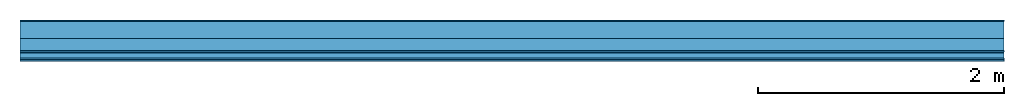
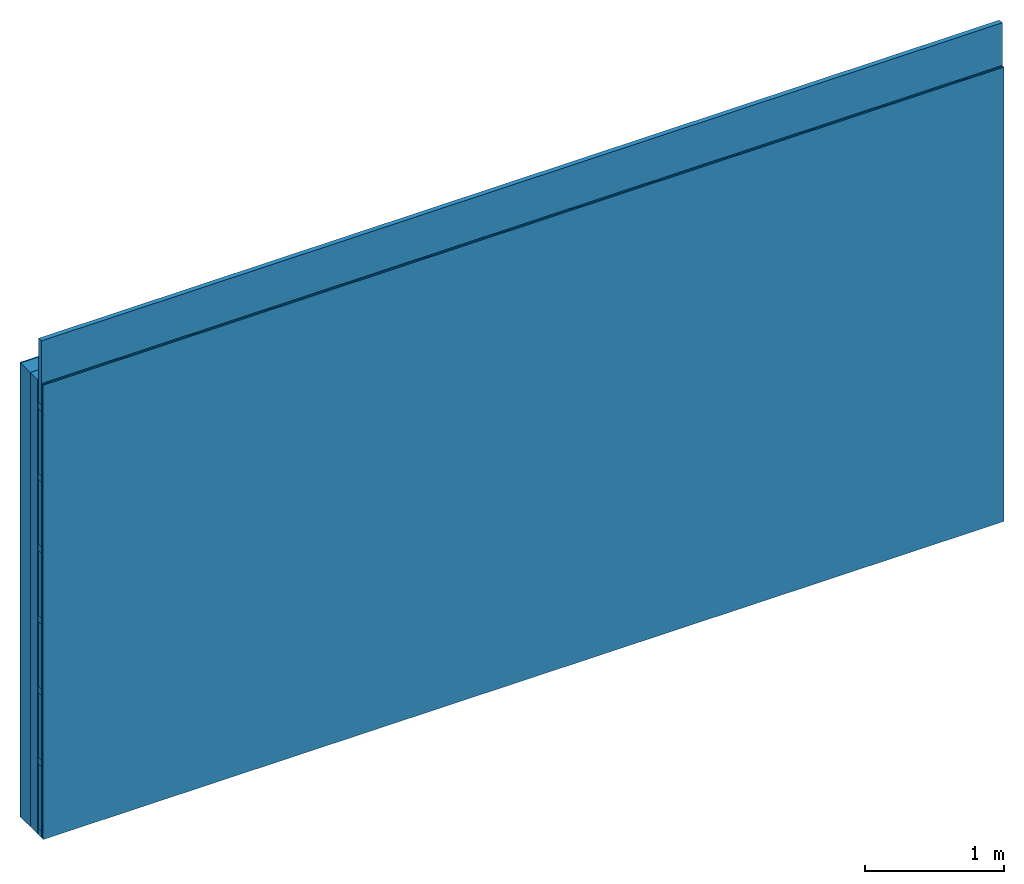
# One storey: 5 plates, 3 members, 1 element without a shape of its own.
"""IFC4 building model written with IfcOpenShell, lengths in metres."""

from ifc_helpers import new_model, si_unit, derived_unit, direction, frame, frame_2d, origin, origin_with_axes, place, context, project, spatial, rectangle, extrude, material, layer, layer_set, type_object, element, aggregate, save


model = new_model("IFC4")

# Units and contexts
plan_context = context("Plan", 3, precision=1e-05, world=origin(), true_north=direction((0.0, 1.0)))
model_context = context("Model", 3, precision=1e-05, world=origin(), true_north=direction((0.0, 1.0)))
ifc_project = project(units=[si_unit("LENGTHUNIT", "METRE"), derived_unit("SOUNDPRESSUREUNIT", [(si_unit("PRESSUREUNIT", "PASCAL", prefix="MICRO"), 0)]), si_unit("ENERGYUNIT", "JOULE", prefix="MEGA"), si_unit("MASSUNIT", "GRAM", prefix="KILO"), derived_unit("THERMALTRANSMITTANCEUNIT", [(si_unit("POWERUNIT", "WATT"), 1), (si_unit("AREAUNIT", "SQUARE_METRE"), -1), (si_unit("THERMODYNAMICTEMPERATUREUNIT", "KELVIN"), -1)]), derived_unit("AREADENSITYUNIT", [(si_unit("MASSUNIT", "GRAM", prefix="KILO"), 1), (si_unit("AREAUNIT", "SQUARE_METRE"), -1)]), derived_unit("USERDEFINED", [(si_unit("ENERGYUNIT", "JOULE", prefix="MEGA"), 1), (si_unit("AREAUNIT", "SQUARE_METRE"), -1)])], contexts=[plan_context, model_context])

# Site, building, storey
site = spatial("IfcSite", under=ifc_project)
building_placement = place(None, origin())
building = spatial("IfcBuilding", under=site, at=building_placement)
storey_placement = place(building_placement, origin())
storey = spatial("IfcBuildingStorey", under=building, at=storey_placement)

# Wall, members, plates
ifc_material_1 = material(Name="Mineral Knauf SM 700")
ifc_layer_1 = layer(ifc_material_1, 0.01, Name="Surface 1")
ifc_material_2 = material(Category="10.008")
ifc_layer_2 = layer(ifc_material_2, 0.14, Name="outside 1st layer")
ifc_material_3 = material(Name="of the art")
ifc_layer_3 = layer(ifc_material_3, 0.0, Name="Bond")
ifc_layer_4 = layer(None, 0.1, Name="Support")
ifc_material_4 = material(Name="Air")
ifc_layer_5 = layer(ifc_material_4, 0.01, Name="Coupling")
ifc_layer_6 = layer(None, 0.05, Name="Battens / profiles")
ifc_material_5 = material(Category="03.008")
ifc_layer_7 = layer(ifc_material_5, 0.0125, Name="Covering 1st layer")
ifc_layer_8 = layer(ifc_material_5, 0.0125, Name="Covering 2nd layer")
ifc_layer_set = layer_set([ifc_layer_1, ifc_layer_2, ifc_layer_3, ifc_layer_4, ifc_layer_5, ifc_layer_6, ifc_layer_7, ifc_layer_8])
wall_type = type_object("IfcWallType", Name="D1198", PredefinedType="NOTDEFINED", material=ifc_layer_set)
wall_placement = place(None, frame((0.0, 0.0, 0.0), z_axis=(0.0, -1.0, 0.0), x_axis=(1.0, 0.0, 0.0)))
wall = element("IfcWall", 1, at=wall_placement, inside=storey, type_object=wall_type, material=ifc_layer_set, Name="Wall #1")
ifc_material_6 = material(Name="OSB")
member_1_placement = place(wall_placement, origin())
member_1 = element("IfcMember", 2, at=member_1_placement, material=ifc_material_6, Name="Support", context=plan_context, shape_type="SweptSolid", body=[
    extrude(rectangle(XDim=1.0, YDim=0.1, at=frame_2d((0.5, 0.05), x_axis=(1.0, 0.0))), frame((0.0, 4.0, 0.15), z_axis=(0.0, -1.0, 0.0), x_axis=(1.0, 0.0, 0.0)), (0.0, 0.0, 1.0), 4.0),
    extrude(rectangle(XDim=1.0, YDim=0.1, at=frame_2d((0.5, 0.05), x_axis=(1.0, 0.0))), frame((1.0, 4.0, 0.15), z_axis=(0.0, -1.0, 0.0), x_axis=(1.0, 0.0, 0.0)), (0.0, 0.0, 1.0), 4.0),
    extrude(rectangle(XDim=1.0, YDim=0.1, at=frame_2d((0.5, 0.05), x_axis=(1.0, 0.0))), frame((2.0, 4.0, 0.15), z_axis=(0.0, -1.0, 0.0), x_axis=(1.0, 0.0, 0.0)), (0.0, 0.0, 1.0), 4.0),
    extrude(rectangle(XDim=1.0, YDim=0.1, at=frame_2d((0.5, 0.05), x_axis=(1.0, 0.0))), frame((3.0, 4.0, 0.15), z_axis=(0.0, -1.0, 0.0), x_axis=(1.0, 0.0, 0.0)), (0.0, 0.0, 1.0), 4.0),
    extrude(rectangle(XDim=1.0, YDim=0.1, at=frame_2d((0.5, 0.05), x_axis=(1.0, 0.0))), frame((4.0, 4.0, 0.15), z_axis=(0.0, -1.0, 0.0), x_axis=(1.0, 0.0, 0.0)), (0.0, 0.0, 1.0), 4.0),
    extrude(rectangle(XDim=1.0, YDim=0.1, at=frame_2d((0.5, 0.05), x_axis=(1.0, 0.0))), frame((5.0, 4.0, 0.15), z_axis=(0.0, -1.0, 0.0), x_axis=(1.0, 0.0, 0.0)), (0.0, 0.0, 1.0), 4.0),
    extrude(rectangle(XDim=1.0, YDim=0.1, at=frame_2d((0.5, 0.05), x_axis=(1.0, 0.0))), frame((6.0, 4.0, 0.15), z_axis=(0.0, -1.0, 0.0), x_axis=(1.0, 0.0, 0.0)), (0.0, 0.0, 1.0), 4.0),
    extrude(rectangle(XDim=1.0, YDim=0.1, at=frame_2d((0.5, 0.05), x_axis=(1.0, 0.0))), frame((7.0, 4.0, 0.15), z_axis=(0.0, -1.0, 0.0), x_axis=(1.0, 0.0, 0.0)), (0.0, 0.0, 1.0), 4.0),
])
ifc_material_7 = material()
member_2_placement = place(wall_placement, origin())
member_2 = element("IfcMember", 3, at=member_2_placement, material=ifc_material_7, Name="Battens / profiles", context=plan_context, shape_type="SweptSolid", body=[
    extrude(rectangle(XDim=0.06, YDim=0.05, at=frame_2d((0.03, 0.025), x_axis=(1.0, 0.0))), frame((0.0, 0.0, 0.26), z_axis=(1.0, 0.0, 0.0), x_axis=(0.0, 1.0, 0.0)), (0.0, 0.0, 1.0), 8.0),
    extrude(rectangle(XDim=0.06, YDim=0.05, at=frame_2d((0.03, 0.025), x_axis=(1.0, 0.0))), frame((0.0, 0.625, 0.26), z_axis=(1.0, 0.0, 0.0), x_axis=(0.0, 1.0, 0.0)), (0.0, 0.0, 1.0), 8.0),
    extrude(rectangle(XDim=0.06, YDim=0.05, at=frame_2d((0.03, 0.025), x_axis=(1.0, 0.0))), frame((0.0, 1.25, 0.26), z_axis=(1.0, 0.0, 0.0), x_axis=(0.0, 1.0, 0.0)), (0.0, 0.0, 1.0), 8.0),
    extrude(rectangle(XDim=0.06, YDim=0.05, at=frame_2d((0.03, 0.025), x_axis=(1.0, 0.0))), frame((0.0, 1.875, 0.26), z_axis=(1.0, 0.0, 0.0), x_axis=(0.0, 1.0, 0.0)), (0.0, 0.0, 1.0), 8.0),
    extrude(rectangle(XDim=0.06, YDim=0.05, at=frame_2d((0.03, 0.025), x_axis=(1.0, 0.0))), frame((0.0, 2.5, 0.26), z_axis=(1.0, 0.0, 0.0), x_axis=(0.0, 1.0, 0.0)), (0.0, 0.0, 1.0), 8.0),
    extrude(rectangle(XDim=0.06, YDim=0.05, at=frame_2d((0.03, 0.025), x_axis=(1.0, 0.0))), frame((0.0, 3.125, 0.26), z_axis=(1.0, 0.0, 0.0), x_axis=(0.0, 1.0, 0.0)), (0.0, 0.0, 1.0), 8.0),
    extrude(rectangle(XDim=0.06, YDim=0.05, at=frame_2d((0.03, 0.025), x_axis=(1.0, 0.0))), frame((0.0, 3.75, 0.26), z_axis=(1.0, 0.0, 0.0), x_axis=(0.0, 1.0, 0.0)), (0.0, 0.0, 1.0), 8.0),
])
ifc_material_8 = material(Name="MINERAL PLUS KP 034")
member_3_placement = place(wall_placement, origin())
member_3 = element("IfcMember", 4, at=member_3_placement, material=ifc_material_8, Name="Cavity", context=plan_context, shape_type="SweptSolid", body=[
    extrude(rectangle(XDim=0.565, YDim=0.04, at=frame_2d((0.2825, 0.02), x_axis=(1.0, 0.0))), frame((0.0, 0.06, 0.27), z_axis=(1.0, 0.0, 0.0), x_axis=(0.0, 1.0, 0.0)), (0.0, 0.0, 1.0), 8.0),
    extrude(rectangle(XDim=0.565, YDim=0.04, at=frame_2d((0.2825, 0.02), x_axis=(1.0, 0.0))), frame((0.0, 0.685, 0.27), z_axis=(1.0, 0.0, 0.0), x_axis=(0.0, 1.0, 0.0)), (0.0, 0.0, 1.0), 8.0),
    extrude(rectangle(XDim=0.565, YDim=0.04, at=frame_2d((0.2825, 0.02), x_axis=(1.0, 0.0))), frame((0.0, 1.31, 0.27), z_axis=(1.0, 0.0, 0.0), x_axis=(0.0, 1.0, 0.0)), (0.0, 0.0, 1.0), 8.0),
    extrude(rectangle(XDim=0.565, YDim=0.04, at=frame_2d((0.2825, 0.02), x_axis=(1.0, 0.0))), frame((0.0, 1.935, 0.27), z_axis=(1.0, 0.0, 0.0), x_axis=(0.0, 1.0, 0.0)), (0.0, 0.0, 1.0), 8.0),
    extrude(rectangle(XDim=0.565, YDim=0.04, at=frame_2d((0.2825, 0.02), x_axis=(1.0, 0.0))), frame((0.0, 2.56, 0.27), z_axis=(1.0, 0.0, 0.0), x_axis=(0.0, 1.0, 0.0)), (0.0, 0.0, 1.0), 8.0),
    extrude(rectangle(XDim=0.565, YDim=0.04, at=frame_2d((0.2825, 0.02), x_axis=(1.0, 0.0))), frame((0.0, 3.185, 0.27), z_axis=(1.0, 0.0, 0.0), x_axis=(0.0, 1.0, 0.0)), (0.0, 0.0, 1.0), 8.0),
    extrude(rectangle(XDim=0.565, YDim=0.04, at=frame_2d((0.2825, 0.02), x_axis=(1.0, 0.0))), frame((0.0, 3.81, 0.27), z_axis=(1.0, 0.0, 0.0), x_axis=(0.0, 1.0, 0.0)), (0.0, 0.0, 1.0), 8.0),
])
plate_1_placement = place(wall_placement, origin())
plate_1 = element("IfcPlate", 5, at=plate_1_placement, material=ifc_material_1, Name="Surface 1", context=plan_context, shape_type="SweptSolid", body=[
    extrude(rectangle(XDim=8.0, YDim=4.0, at=frame_2d((4.0, 2.0), x_axis=(1.0, 0.0))), origin_with_axes(), (0.0, 0.0, 1.0), 0.01),
])
plate_2_placement = place(wall_placement, origin())
plate_2 = element("IfcPlate", 6, at=plate_2_placement, material=ifc_material_2, Name="outside 1st layer", context=plan_context, shape_type="SweptSolid", body=[
    extrude(rectangle(XDim=8.0, YDim=4.0, at=frame_2d((4.0, 2.0), x_axis=(1.0, 0.0))), frame((0.0, 0.0, 0.01), z_axis=(0.0, 0.0, 1.0), x_axis=(1.0, 0.0, 0.0)), (0.0, 0.0, 1.0), 0.14),
])
plate_3_placement = place(wall_placement, origin())
plate_3 = element("IfcPlate", 7, at=plate_3_placement, material=ifc_material_4, Name="Coupling", context=plan_context, shape_type="SweptSolid", body=[
    extrude(rectangle(XDim=8.0, YDim=4.0, at=frame_2d((4.0, 2.0), x_axis=(1.0, 0.0))), frame((0.0, 0.0, 0.25), z_axis=(0.0, 0.0, 1.0), x_axis=(1.0, 0.0, 0.0)), (0.0, 0.0, 1.0), 0.01),
])
plate_4_placement = place(wall_placement, origin())
plate_4 = element("IfcPlate", 8, at=plate_4_placement, material=ifc_material_5, Name="Covering 1st layer", context=plan_context, shape_type="SweptSolid", body=[
    extrude(rectangle(XDim=8.0, YDim=4.0, at=frame_2d((4.0, 2.0), x_axis=(1.0, 0.0))), frame((0.0, 0.0, 0.31), z_axis=(0.0, 0.0, 1.0), x_axis=(1.0, 0.0, 0.0)), (0.0, 0.0, 1.0), 0.0125),
])
plate_5_placement = place(wall_placement, origin())
plate_5 = element("IfcPlate", 9, at=plate_5_placement, material=ifc_material_5, Name="Covering 2nd layer", context=plan_context, shape_type="SweptSolid", body=[
    extrude(rectangle(XDim=8.0, YDim=4.0, at=frame_2d((4.0, 2.0), x_axis=(1.0, 0.0))), frame((0.0, 0.0, 0.3225), z_axis=(0.0, 0.0, 1.0), x_axis=(1.0, 0.0, 0.0)), (0.0, 0.0, 1.0), 0.0125),
])
aggregate(wall, [plate_1, plate_2, member_1, plate_3, member_2, member_3, plate_4, plate_5])

save(model, "model.ifc")
